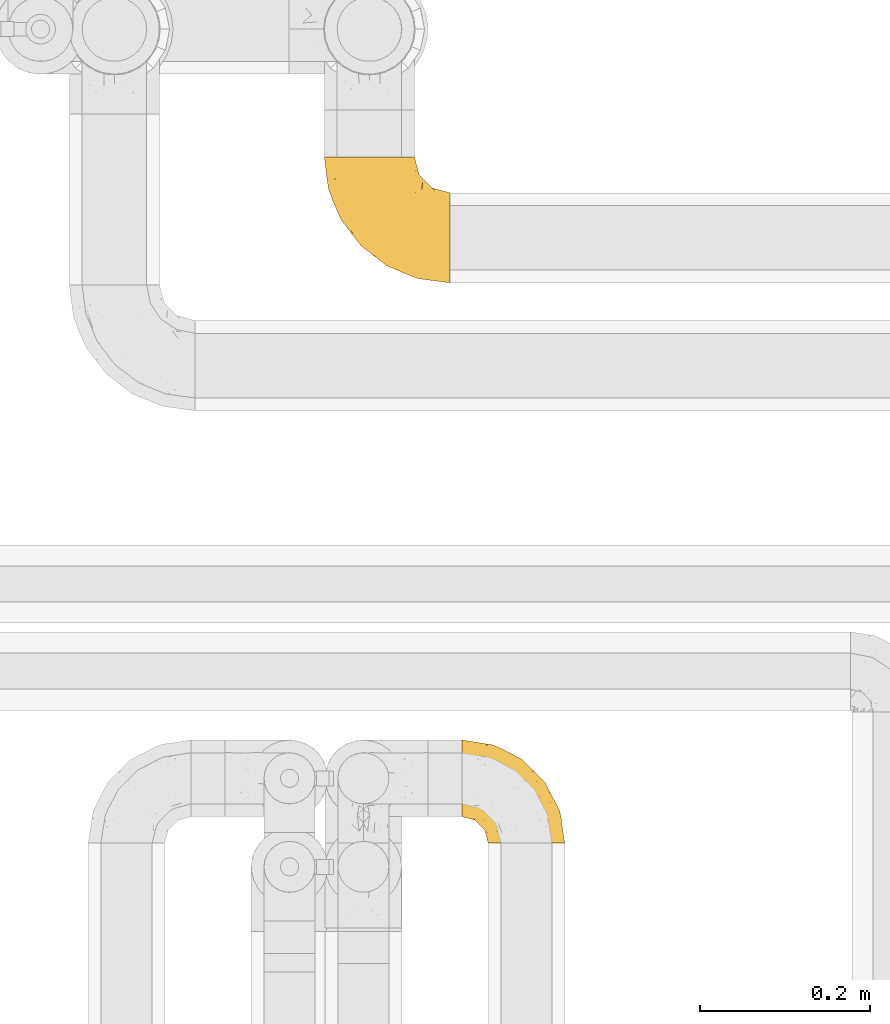
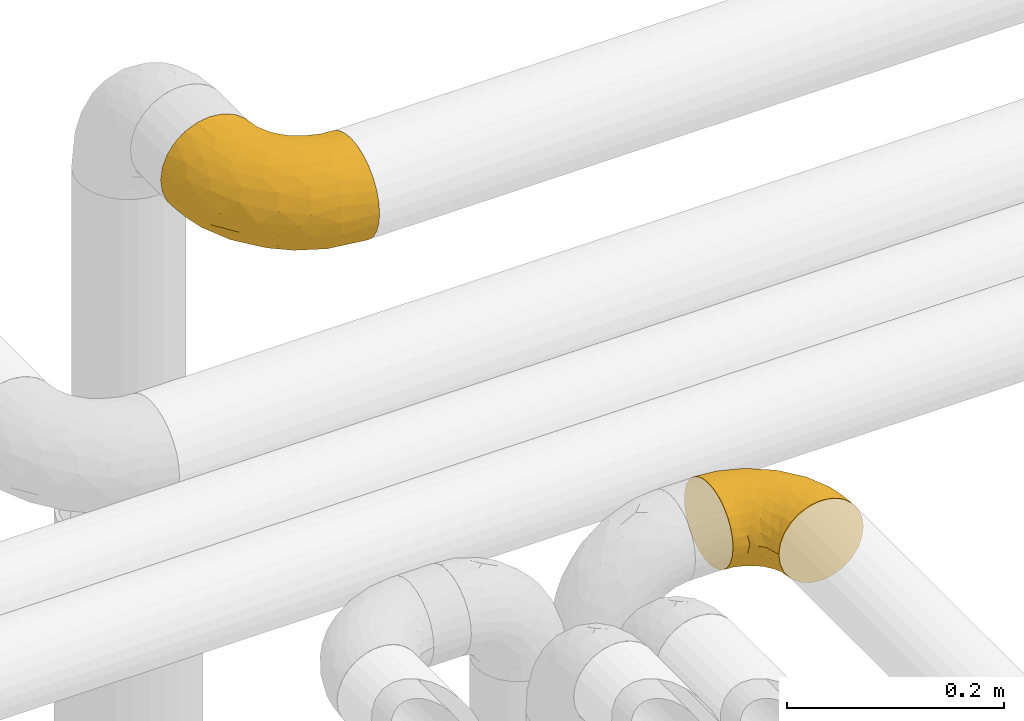
# One storey, part 323 of 827: 2 coverings.
"""IFC2X3 building model written with IfcOpenShell, lengths in millimetres."""

import ifcopenshell
import ifcopenshell.guid

model = None  # the IFC model being written
_history = None  # IfcOwnerHistory: only IFC2X3 demands one
_inside = {}  # id of a spatial element -> (the spatial element, [elements in it])
_under = {}  # id of a project, library or spatial element -> (it, [spatial elements below it])
_declared = {}  # id of a project -> (the project, [libraries it declares])
_typed = {}  # id of a type object -> (the type object, [elements of that type])
_made_of = {}  # id of a material, layer set ... -> (it, [elements and type objects made of it])


def new_model(schema):
    """Start an empty IFC model of exactly this schema.

    Asked for "IFC4X3", IfcOpenShell would pick the latest addendum, in which some entities
    have other attributes; the version numbers below select the first issue.
    IFC2X3 requires an IfcOwnerHistory on every rooted entity: one is made here for all.
    """
    global model, _history
    if schema == "IFC4X3":
        model = ifcopenshell.file(schema_version=(4, 3, 0, 0))
    else:
        model = ifcopenshell.file(schema=schema)
    _inside.clear()
    _under.clear()
    _declared.clear()
    _typed.clear()
    _made_of.clear()
    _history = None
    if model.schema == "IFC2X3":
        org = make("IfcOrganization", Name="unknown")
        user = make(
            "IfcPersonAndOrganization",
            ThePerson=make("IfcPerson", FamilyName="unknown"),
            TheOrganization=org,
        )
        app = make(
            "IfcApplication",
            ApplicationDeveloper=org,
            Version="unknown",
            ApplicationFullName="unknown",
            ApplicationIdentifier="unknown",
        )
        _history = make(
            "IfcOwnerHistory",
            OwningUser=user,
            OwningApplication=app,
            ChangeAction="ADDED",
            CreationDate=0,
        )
    return model


def make(cls, **values):
    """One entity of the class cls with the attributes given. An attribute that is None is left unset."""
    return model.create_entity(
        cls, **{name: value for name, value in values.items() if value is not None}
    )


def entity(cls, *values):
    """Any entity or typed value of the class cls, its attributes in the order of the schema. None: left unset."""
    e = model.create_entity(cls)
    for i, value in enumerate(values):
        if value is not None:
            e[i] = value
    return e


def rooted(cls, **values):
    """An entity with a GlobalId (a new one), such as an element, a storey or a relation."""
    return make(cls, GlobalId=ifcopenshell.guid.new(), OwnerHistory=_history, **values)


def si_unit(unit_type, name, prefix=None):
    """IfcSIUnit, for example si_unit("LENGTHUNIT", "METRE", prefix="MILLI")."""
    return make("IfcSIUnit", UnitType=unit_type, Prefix=prefix, Name=name)


def converted_unit(unit_type, name, factor, base, dimensions=None, offset=None):
    """IfcConversionBasedUnit, such as the inch: factor (a typed value) times the base unit."""
    return make(
        "IfcConversionBasedUnit"
        if offset is None
        else "IfcConversionBasedUnitWithOffset",
        ConversionOffset=offset,
        Dimensions=None
        if dimensions is None
        else entity("IfcDimensionalExponents", *dimensions),
        UnitType=unit_type,
        Name=name,
        ConversionFactor=make(
            "IfcMeasureWithUnit", ValueComponent=factor, UnitComponent=base
        ),
    )


def derived_unit(unit_type, elements):
    """IfcDerivedUnit: a product of units, each with its exponent."""
    return make(
        "IfcDerivedUnit",
        Elements=[
            make("IfcDerivedUnitElement", Unit=unit, Exponent=power)
            for unit, power in elements
        ],
        UnitType=unit_type,
    )


def assignment(units):
    """IfcUnitAssignment: the units of a project."""
    return None if units is None else make("IfcUnitAssignment", Units=units)


def point(xyz):
    """IfcCartesianPoint."""
    return None if xyz is None else make("IfcCartesianPoint", Coordinates=xyz)


def direction(xyz):
    """IfcDirection."""
    return None if xyz is None else make("IfcDirection", DirectionRatios=xyz)


def frame(location, z_axis=None, x_axis=None):
    """IfcAxis2Placement3D, a coordinate frame: its origin and axes. An axis left out is left unset."""
    return make(
        "IfcAxis2Placement3D",
        Location=point(location),
        Axis=direction(z_axis),
        RefDirection=direction(x_axis),
    )


def origin():
    """The frame at (0, 0, 0) with its axes left unset."""
    return frame((0.0, 0.0, 0.0))


def place(relative_to, where):
    """IfcLocalPlacement: puts the frame where relative to a parent placement (None: the world)."""
    return make(
        "IfcLocalPlacement", PlacementRelTo=relative_to, RelativePlacement=where
    )


def context(
    kind, dimensions, precision=None, world=None, true_north=None, identifier=None
):
    """IfcGeometricRepresentationContext, for example the 3D "Model" context."""
    return make(
        "IfcGeometricRepresentationContext",
        ContextIdentifier=identifier,
        ContextType=kind,
        CoordinateSpaceDimension=dimensions,
        Precision=precision,
        WorldCoordinateSystem=world,
        TrueNorth=true_north,
    )


def subcontext(parent, identifier, kind, view, scale=None):
    """IfcGeometricRepresentationSubContext, for example "Body" below "Model"."""
    return make(
        "IfcGeometricRepresentationSubContext",
        ContextIdentifier=identifier,
        ContextType=kind,
        ParentContext=parent,
        TargetScale=scale,
        TargetView=view,
    )


def project(units=None, contexts=None):
    """IfcProject with its units and contexts."""
    return rooted(
        "IfcProject",
        Name="project",
        RepresentationContexts=contexts,
        UnitsInContext=assignment(units),
    )


def spatial(cls, under=None, at=None, **own):
    """A site, building, storey or space (cls), placed at a placement, below another one or the project."""
    s = rooted(cls, ObjectPlacement=at, **own)
    if under is not None:
        _under.setdefault(under.id(), (under, []))[1].append(s)
    return s


def faces_of(points, faces, orient=None, outer=None):
    """IfcFace entities. A face is a list of loops; a loop is a list of indices into points, from 0.

    orient and outer hold one flag for each loop. By default every Orientation is true, the
    first loop of a face is its IfcFaceOuterBound and the others are IfcFaceBound.
    """
    made = []
    for i, loops in enumerate(faces):
        bounds = []
        for j, loop in enumerate(loops):
            is_outer = j == 0 if outer is None else outer[i][j]
            bounds.append(
                make(
                    "IfcFaceOuterBound" if is_outer else "IfcFaceBound",
                    Bound=make("IfcPolyLoop", Polygon=[points[k] for k in loop]),
                    Orientation=True if orient is None else orient[i][j],
                )
            )
        made.append(make("IfcFace", Bounds=bounds))
    return made


def faceted_brep(points, faces, orient=None, outer=None, voids=None):
    """IfcFacetedBrep: a solid bounded by flat faces; with voids (closed shells), ...WithVoids."""
    shared = [point(p) for p in points]
    hull = make("IfcClosedShell", CfsFaces=faces_of(shared, faces, orient, outer))
    if voids is None:
        return make("IfcFacetedBrep", Outer=hull)
    return make(
        "IfcFacetedBrepWithVoids",
        Outer=hull,
        Voids=[
            make(cls, CfsFaces=faces_of(shared, fs, o, b)) for cls, fs, o, b in voids
        ],
    )


def shape(context_of_items, identifier, shape_type, items):
    """IfcShapeRepresentation: the items that make up one representation, for example the "Body"."""
    return make(
        "IfcShapeRepresentation",
        ContextOfItems=context_of_items,
        RepresentationIdentifier=identifier,
        RepresentationType=shape_type,
        Items=items,
    )


def made_of(thing, what):
    """Note that an element or type object is made of a material, layer set ...; save() writes the relation."""
    if what is not None:
        _made_of.setdefault(what.id(), (what, []))[1].append(thing)
    return thing


def element(
    cls,
    number,
    at=None,
    inside=None,
    cuts=None,
    type_object=None,
    material=None,
    context=None,
    identifier="Body",
    shape_type=None,
    held_by="IfcProductDefinitionShape",
    body=None,
    shapes=None,
    **own,
):
    """One element of the class cls, such as IfcWall. Its Tag is "e" and its number.

    at: its placement. inside: the storey or other place that contains it. cuts: it is an
    opening in that element (IfcRelVoidsElement). A single representation is given by context,
    identifier, shape_type and body (its items); several are given by shapes. held_by: the class
    of the entity that holds the representations. save() writes the other relations.
    """
    e = rooted(cls, Tag="e%d" % number, ObjectPlacement=at, **own)
    if body is not None:
        shapes = [shape(context, identifier, shape_type, body)]
    if shapes is not None:
        e.Representation = make(held_by, Representations=shapes)
    if inside is not None:
        _inside.setdefault(inside.id(), (inside, []))[1].append(e)
    if cuts is not None:
        rooted(
            "IfcRelVoidsElement", RelatingBuildingElement=cuts, RelatedOpeningElement=e
        )
    if type_object is not None:
        _typed.setdefault(type_object.id(), (type_object, []))[1].append(e)
    return made_of(e, material)


def aggregate(whole, parts):
    """IfcRelAggregates: a whole, such as a stair, and the parts it consists of."""
    return rooted("IfcRelAggregates", RelatingObject=whole, RelatedObjects=parts)


def save(model, path):
    """Write the relations noted so far, then the file.

    IfcRelAggregates (storeys below a building ...), IfcRelContainedInSpatialStructure (elements
    in a storey), IfcRelDefinesByType, IfcRelAssociatesMaterial and IfcRelDeclares: one each for
    every whole, place, type object, material and project.
    """
    for whole, parts in _under.values():
        aggregate(whole, parts)
    for where, things in _inside.values():
        rooted(
            "IfcRelContainedInSpatialStructure",
            RelatedElements=things,
            RelatingStructure=where,
        )
    for kind, things in _typed.values():
        rooted("IfcRelDefinesByType", RelatedObjects=things, RelatingType=kind)
    for what, things in _made_of.values():
        rooted("IfcRelAssociatesMaterial", RelatedObjects=things, RelatingMaterial=what)
    for by, libraries in _declared.values():
        rooted("IfcRelDeclares", RelatingContext=by, RelatedDefinitions=libraries)
    model.write(path)


model = new_model("IFC2X3")

# Units and contexts
model_context = context("Model", 3, precision=0.01, world=origin(), true_north=direction((6.12303176911189e-17, 1.0)))
body_context = subcontext(model_context, "Body", "Model", "MODEL_VIEW")
ifc_project = project(units=[si_unit("LENGTHUNIT", "METRE", prefix="MILLI"), si_unit("AREAUNIT", "SQUARE_METRE"), si_unit("VOLUMEUNIT", "CUBIC_METRE"), converted_unit("PLANEANGLEUNIT", "DEGREE", entity("IfcRatioMeasure", 0.0174532925199433), si_unit("PLANEANGLEUNIT", "RADIAN"), dimensions=[0, 0, 0, 0, 0, 0, 0]), si_unit("MASSUNIT", "GRAM", prefix="KILO"), derived_unit("MASSDENSITYUNIT", [(si_unit("MASSUNIT", "GRAM", prefix="KILO"), 1), (si_unit("LENGTHUNIT", "METRE"), -3)]), derived_unit("MOMENTOFINERTIAUNIT", [(si_unit("LENGTHUNIT", "METRE"), 4)]), si_unit("TIMEUNIT", "SECOND"), si_unit("FREQUENCYUNIT", "HERTZ"), si_unit("THERMODYNAMICTEMPERATUREUNIT", "DEGREE_CELSIUS"), derived_unit("THERMALTRANSMITTANCEUNIT", [(si_unit("MASSUNIT", "GRAM", prefix="KILO"), 1), (si_unit("THERMODYNAMICTEMPERATUREUNIT", "KELVIN"), -1), (si_unit("TIMEUNIT", "SECOND"), -3)]), derived_unit("VOLUMETRICFLOWRATEUNIT", [(si_unit("LENGTHUNIT", "METRE"), 3), (si_unit("TIMEUNIT", "SECOND"), -1)]), derived_unit("MASSFLOWRATEUNIT", [(si_unit("MASSUNIT", "GRAM", prefix="KILO"), 1), (si_unit("TIMEUNIT", "SECOND"), -1)]), derived_unit("ROTATIONALFREQUENCYUNIT", [(si_unit("TIMEUNIT", "SECOND"), -1)]), si_unit("ELECTRICCURRENTUNIT", "AMPERE"), si_unit("ELECTRICVOLTAGEUNIT", "VOLT"), si_unit("POWERUNIT", "WATT"), si_unit("FORCEUNIT", "NEWTON", prefix="KILO"), si_unit("ILLUMINANCEUNIT", "LUX"), si_unit("LUMINOUSFLUXUNIT", "LUMEN"), si_unit("LUMINOUSINTENSITYUNIT", "CANDELA"), derived_unit("USERDEFINED", [(si_unit("MASSUNIT", "GRAM", prefix="KILO"), -1), (si_unit("LENGTHUNIT", "METRE"), -2), (si_unit("TIMEUNIT", "SECOND"), 3), (si_unit("LUMINOUSFLUXUNIT", "LUMEN"), 1)]), derived_unit("LINEARVELOCITYUNIT", [(si_unit("LENGTHUNIT", "METRE"), 1), (si_unit("TIMEUNIT", "SECOND"), -1)]), si_unit("PRESSUREUNIT", "PASCAL"), derived_unit("USERDEFINED", [(si_unit("LENGTHUNIT", "METRE"), -2), (si_unit("MASSUNIT", "GRAM", prefix="KILO"), 1), (si_unit("TIMEUNIT", "SECOND"), -2)]), derived_unit("LINEARFORCEUNIT", [(si_unit("MASSUNIT", "GRAM", prefix="KILO"), 1), (si_unit("LENGTHUNIT", "METRE"), 1), (si_unit("TIMEUNIT", "SECOND"), -2), (si_unit("LENGTHUNIT", "METRE"), -1)]), derived_unit("PLANARFORCEUNIT", [(si_unit("MASSUNIT", "GRAM", prefix="KILO"), 1), (si_unit("LENGTHUNIT", "METRE"), 1), (si_unit("TIMEUNIT", "SECOND"), -2), (si_unit("LENGTHUNIT", "METRE"), -2)])], contexts=[model_context])

# Site, building, storey
site_placement = place(None, origin())
site = spatial("IfcSite", under=ifc_project, at=site_placement, CompositionType="ELEMENT")
building_placement = place(site_placement, origin())
building = spatial("IfcBuilding", under=site, at=building_placement, CompositionType="ELEMENT")
storey_placement = place(building_placement, frame((0.0, 0.0, 28200.0)))
storey = spatial("IfcBuildingStorey", under=building, at=storey_placement, Name="08", CompositionType="ELEMENT", Elevation=28200.0)

# Coverings
covering_1_placement = place(storey_placement, frame((31701.06, 19053.07, 2945.35)))
element("IfcCovering", 1, at=covering_1_placement, inside=storey, Name=":ADSK_", ObjectType=":ADSK_", PredefinedType="INSULATION", context=body_context, shape_type="Brep", body=[
    faceted_brep([(149.65, 2.92, 66.44), (149.65, 1.6, 54.65), (149.65, 2.93, 42.84), (149.65, 6.85, 31.62), (149.65, 13.18, 21.56), (149.65, 21.58, 13.16), (149.65, 31.64, 6.84), (149.65, 42.85, 2.92), (149.65, 54.65, 1.6), (149.65, 66.46, 2.93), (149.65, 77.67, 6.85), (149.65, 87.73, 13.18), (149.65, 96.13, 21.58), (149.65, 102.45, 31.64), (149.65, 106.37, 42.85), (149.65, 107.7, 54.65), (149.65, 106.36, 66.46), (149.65, 102.44, 77.67), (149.65, 96.11, 87.73), (149.65, 87.71, 96.13), (149.65, 77.65, 102.45), (149.65, 66.44, 106.37), (149.65, 54.65, 107.7), (149.65, 42.84, 106.36), (149.65, 31.62, 102.44), (149.65, 21.56, 96.11), (149.65, 13.16, 87.71), (149.65, 6.84, 77.65), (105.89, 149.65, 40.91), (100.59, 149.65, 28.12), (92.16, 149.65, 17.13), (81.17, 149.65, 8.7), (68.38, 149.65, 3.4), (54.65, 149.65, 1.6), (40.91, 149.65, 3.4), (28.12, 149.65, 8.7), (17.13, 149.65, 17.13), (8.7, 149.65, 28.12), (3.4, 149.65, 40.91), (1.6, 149.65, 54.65), (3.4, 149.65, 68.38), (8.7, 149.65, 81.17), (17.13, 149.65, 92.16), (28.12, 149.65, 100.59), (40.91, 149.65, 105.89), (54.65, 149.65, 107.7), (68.38, 149.65, 105.89), (81.17, 149.65, 100.59), (92.16, 149.65, 92.16), (100.59, 149.65, 81.17), (105.89, 149.65, 68.38), (107.7, 149.65, 54.65), (14.05, 123.27, 85.53), (9.45, 114.15, 73.42), (22.36, 92.97, 83.77), (4.7, 124.11, 64.22), (6.64, 111.33, 54.65), (81.47, 42.13, 96.72), (56.83, 56.83, 93.36), (64.02, 40.31, 84.47), (34.04, 61.55, 71.37), (21.43, 75.62, 54.65), (44.96, 44.96, 54.65), (49.8, 91.12, 103.47), (35.43, 109.83, 100.91), (42.1, 88.02, 99.1), (43.59, 119.19, 105.43), (57.88, 99.11, 106.79), (91.8, 27.97, 89.81), (88.01, 21.92, 79.59), (115.65, 12.94, 81.29), (18.94, 88.29, 74.01), (12.83, 95.35, 64.14), (24.96, 113.84, 94.75), (111.33, 6.64, 54.65), (113.8, 8.58, 70.74), (60.89, 33.39, 68.3), (86.24, 17.23, 66.05), (65.84, 61.99, 100.73), (124.58, 47.9, 106.78), (121.36, 37.72, 103.6), (72.79, 93.81, 107.7), (66.04, 107.05, 107.7), (59.29, 120.29, 107.7), (73.26, 73.26, 106.07), (121.69, 18.58, 90.59), (109.82, 29.72, 97.43), (40.11, 64.31, 84.51), (36.57, 82.84, 93.3), (93.81, 72.79, 107.7), (83.3, 83.3, 107.7), (136.6, 56.71, 107.7), (120.29, 59.29, 107.7), (99.11, 57.88, 106.79), (107.05, 66.04, 107.7), (91.12, 49.8, 103.47), (75.62, 21.43, 54.65), (56.97, 134.97, 107.7), (126.65, 108.79, 76.99), (116.55, 110.84, 84.28), (120.09, 101.53, 91.11), (76.06, 111.84, 106.26), (83.69, 119.98, 102.6), (71.88, 123.54, 106.08), (66.92, 134.54, 106.56), (110.43, 80.57, 105.36), (121.31, 69.55, 106.74), (81.0, 134.56, 101.59), (113.32, 128.67, 54.65), (111.09, 136.98, 54.65), (109.14, 133.56, 67.71), (95.86, 131.66, 91.36), (99.07, 117.75, 94.33), (106.92, 118.23, 87.1), (131.39, 110.55, 65.84), (136.98, 111.09, 54.65), (128.67, 113.32, 54.65), (117.07, 120.2, 68.92), (96.39, 105.95, 100.82), (106.61, 127.69, 79.83), (103.72, 139.88, 77.13), (92.14, 92.14, 105.9), (107.13, 93.82, 101.53), (98.03, 82.28, 106.72), (88.38, 130.86, 97.75), (130.66, 78.78, 103.08), (135.45, 67.58, 106.39), (123.57, 90.58, 98.1), (137.75, 90.23, 95.02), (133.2, 99.39, 86.9), (138.8, 105.17, 74.42), (120.99, 120.99, 54.65), (84.53, 104.59, 105.28), (108.72, 108.24, 92.87), (95.86, 131.66, 17.93), (130.67, 78.8, 6.22), (109.13, 133.57, 41.58), (93.81, 72.79, 1.6), (98.02, 82.27, 2.57), (110.43, 80.59, 3.94), (131.4, 110.55, 43.46), (126.66, 108.79, 32.32), (117.08, 120.2, 40.38), (108.74, 108.25, 16.44), (96.31, 106.06, 8.47), (99.11, 117.78, 15.01), (123.58, 90.6, 11.21), (107.12, 93.87, 7.78), (72.79, 93.81, 1.6), (66.04, 107.05, 1.6), (76.07, 111.89, 3.04), (56.97, 134.97, 1.6), (66.92, 134.54, 2.73), (120.29, 59.29, 1.6), (107.05, 66.04, 1.6), (121.26, 69.56, 2.55), (84.46, 104.56, 3.98), (83.69, 119.98, 6.69), (81.0, 134.56, 7.7), (71.88, 123.54, 3.21), (137.76, 90.25, 14.28), (133.21, 99.4, 22.42), (116.58, 110.83, 25.02), (120.1, 101.52, 18.18), (138.81, 105.18, 34.89), (136.6, 56.71, 1.6), (103.72, 139.89, 32.17), (106.96, 118.22, 22.23), (135.44, 67.6, 2.91), (88.38, 130.86, 11.54), (83.3, 83.3, 1.6), (92.12, 92.12, 3.38), (106.6, 127.71, 29.46), (59.29, 120.29, 1.6), (22.36, 92.97, 25.52), (14.05, 123.27, 23.76), (24.96, 113.84, 14.54), (35.43, 109.83, 8.38), (4.71, 124.03, 45.07), (9.45, 114.15, 35.87), (11.79, 98.04, 45.14), (57.88, 99.11, 2.5), (124.57, 47.9, 2.51), (121.37, 37.74, 5.68), (91.12, 49.8, 5.82), (56.83, 56.83, 15.93), (81.48, 42.16, 12.54), (64.05, 40.3, 24.81), (99.11, 57.88, 2.5), (73.26, 73.26, 3.22), (43.59, 119.19, 3.86), (19.5, 86.61, 35.85), (91.8, 27.99, 19.47), (121.7, 18.59, 18.68), (88.04, 21.92, 29.68), (123.34, 11.28, 27.95), (60.89, 33.39, 40.99), (34.04, 61.55, 37.92), (109.85, 29.73, 11.85), (42.1, 88.01, 10.19), (65.78, 62.08, 8.55), (113.81, 8.58, 38.53), (36.57, 82.84, 15.99), (40.12, 64.3, 24.79), (49.8, 91.12, 5.82), (86.08, 18.05, 40.56)], [[[0, 1, 2, 3, 4, 5, 6, 7, 8, 9, 10, 11, 12, 13, 14, 15, 16, 17, 18, 19, 20, 21, 22, 23, 24, 25, 26, 27]], [[28, 29, 30, 31, 32, 33, 34, 35, 36, 37, 38, 39, 40, 41, 42, 43, 44, 45, 46, 47, 48, 49, 50, 51]], [[52, 53, 54]], [[55, 39, 56]], [[57, 58, 59]], [[60, 61, 62]], [[63, 64, 65]], [[66, 63, 67]], [[68, 69, 70]], [[53, 71, 54]], [[41, 40, 53]], [[53, 72, 71]], [[73, 42, 52]], [[42, 41, 52]], [[74, 0, 75]], [[69, 76, 77]], [[43, 73, 64]], [[45, 44, 66]], [[57, 78, 58]], [[23, 79, 80]], [[67, 81, 82, 83]], [[67, 84, 81]], [[24, 23, 80]], [[25, 85, 26]], [[86, 85, 25]], [[42, 73, 43]], [[0, 27, 75]], [[25, 24, 86]], [[70, 26, 85]], [[0, 74, 1]], [[68, 85, 86]], [[66, 64, 63]], [[60, 59, 87]], [[54, 87, 88]], [[76, 60, 62]], [[84, 89, 90, 81]], [[79, 22, 91, 92]], [[77, 74, 75]], [[93, 92, 94, 89]], [[80, 86, 24]], [[40, 55, 53]], [[76, 59, 60]], [[93, 84, 95]], [[76, 62, 96]], [[55, 72, 53]], [[70, 27, 26]], [[75, 70, 69]], [[78, 84, 63]], [[93, 79, 92]], [[95, 86, 80]], [[77, 76, 96]], [[59, 69, 68]], [[57, 68, 86]], [[68, 57, 59]], [[59, 58, 87]], [[76, 69, 59]], [[88, 87, 58]], [[87, 54, 71]], [[86, 95, 57]], [[78, 57, 95]], [[84, 78, 95]], [[78, 63, 65]], [[58, 78, 65]], [[54, 88, 73]], [[84, 93, 89]], [[79, 95, 80]], [[79, 93, 95]], [[22, 79, 23]], [[66, 83, 97, 45]], [[84, 67, 63]], [[83, 66, 67]], [[64, 44, 43]], [[64, 66, 44]], [[65, 73, 88]], [[53, 52, 41]], [[73, 52, 54]], [[73, 65, 64]], [[65, 88, 58]], [[39, 55, 40]], [[72, 55, 56]], [[56, 61, 72]], [[60, 72, 61]], [[72, 60, 71]], [[87, 71, 60]], [[27, 70, 75]], [[68, 70, 85]], [[74, 77, 96]], [[69, 77, 75]], [[98, 99, 100]], [[46, 45, 97]], [[101, 102, 103]], [[103, 104, 83]], [[105, 94, 106]], [[107, 103, 102]], [[108, 109, 51, 110]], [[111, 112, 113]], [[114, 115, 116]], [[47, 104, 107]], [[110, 117, 108]], [[49, 48, 111]], [[102, 118, 112]], [[119, 120, 111]], [[50, 49, 120]], [[121, 122, 118]], [[105, 123, 89]], [[124, 48, 107]], [[20, 19, 125]], [[121, 81, 90]], [[117, 119, 99]], [[21, 20, 126]], [[22, 21, 91]], [[105, 125, 127]], [[110, 51, 50]], [[19, 128, 125]], [[16, 15, 115]], [[129, 98, 100]], [[126, 91, 21]], [[128, 129, 127]], [[122, 123, 105]], [[114, 117, 98]], [[17, 16, 130]], [[18, 128, 19]], [[129, 18, 17]], [[125, 106, 126]], [[115, 114, 16]], [[130, 129, 17]], [[114, 98, 130]], [[117, 116, 131, 108]], [[99, 119, 113]], [[122, 121, 123]], [[92, 126, 106]], [[105, 127, 122]], [[132, 121, 118]], [[114, 130, 16]], [[129, 130, 98]], [[50, 120, 110]], [[129, 128, 18]], [[125, 128, 127]], [[125, 126, 20]], [[91, 126, 92]], [[105, 89, 94]], [[105, 106, 125]], [[94, 92, 106]], [[100, 122, 127]], [[118, 122, 133]], [[112, 118, 133]], [[132, 118, 102]], [[132, 102, 101]], [[81, 121, 132]], [[82, 103, 83]], [[132, 101, 81]], [[104, 47, 46]], [[124, 107, 102]], [[48, 47, 107]], [[113, 112, 133]], [[112, 111, 124]], [[99, 113, 133]], [[111, 113, 119]], [[99, 133, 100]], [[117, 99, 98]], [[122, 100, 133]], [[127, 129, 100]], [[103, 82, 101]], [[81, 101, 82]], [[112, 124, 102]], [[48, 124, 111]], [[104, 103, 107]], [[46, 97, 104]], [[111, 120, 49]], [[83, 104, 97]], [[110, 120, 119]], [[117, 110, 119]], [[116, 117, 114]], [[123, 90, 89]], [[90, 123, 121]], [[30, 29, 134]], [[11, 10, 135]], [[51, 109, 108, 136]], [[137, 138, 139]], [[140, 141, 142]], [[143, 144, 145]], [[146, 139, 147]], [[148, 149, 150]], [[151, 32, 152]], [[153, 154, 155]], [[156, 150, 157]], [[158, 157, 159]], [[108, 142, 136]], [[31, 158, 152]], [[160, 161, 12]], [[162, 163, 143]], [[140, 142, 116]], [[142, 141, 162]], [[14, 164, 140]], [[14, 140, 115]], [[9, 8, 165]], [[160, 12, 11]], [[141, 164, 161]], [[13, 12, 161]], [[14, 115, 15]], [[28, 166, 29]], [[135, 139, 146]], [[141, 163, 162]], [[135, 146, 160]], [[143, 167, 162]], [[29, 166, 134]], [[116, 142, 108, 131]], [[165, 153, 168]], [[10, 9, 168]], [[168, 135, 10]], [[138, 147, 139]], [[158, 169, 157]], [[14, 13, 164]], [[116, 115, 140]], [[145, 167, 143]], [[135, 160, 11]], [[168, 153, 155]], [[138, 170, 171]], [[157, 144, 156]], [[147, 144, 143]], [[161, 164, 13]], [[140, 164, 141]], [[142, 172, 136]], [[136, 172, 166]], [[161, 160, 146]], [[165, 168, 9]], [[155, 139, 135]], [[139, 154, 137]], [[168, 155, 135]], [[139, 155, 154]], [[144, 147, 171]], [[163, 147, 143]], [[156, 144, 171]], [[157, 169, 145]], [[171, 148, 156]], [[173, 159, 149]], [[159, 157, 150]], [[152, 159, 173]], [[159, 152, 158]], [[31, 30, 158]], [[169, 30, 134]], [[157, 145, 144]], [[167, 134, 172]], [[134, 167, 145]], [[172, 142, 162]], [[162, 167, 172]], [[163, 141, 161]], [[161, 146, 163]], [[147, 163, 146]], [[148, 150, 156]], [[149, 159, 150]], [[30, 169, 158]], [[145, 169, 134]], [[151, 33, 32]], [[31, 152, 32]], [[152, 173, 151]], [[28, 51, 136]], [[134, 166, 172]], [[28, 136, 166]], [[147, 138, 171]], [[170, 138, 137]], [[170, 148, 171]], [[174, 175, 176]], [[35, 34, 177]], [[178, 179, 180]], [[181, 173, 149, 148]], [[182, 183, 184]], [[185, 186, 187]], [[188, 189, 137]], [[190, 33, 151, 173]], [[191, 179, 174]], [[34, 190, 177]], [[39, 38, 178]], [[192, 193, 194]], [[4, 3, 195]], [[175, 179, 37]], [[38, 37, 179]], [[35, 176, 36]], [[196, 62, 197]], [[181, 190, 173]], [[37, 36, 175]], [[183, 6, 198]], [[189, 148, 170, 137]], [[185, 199, 200]], [[3, 2, 201]], [[202, 185, 203]], [[8, 7, 182]], [[200, 184, 186]], [[183, 7, 6]], [[181, 189, 204]], [[200, 189, 184]], [[5, 198, 6]], [[187, 203, 185]], [[195, 3, 201]], [[205, 196, 194]], [[62, 61, 197]], [[186, 198, 192]], [[180, 179, 191]], [[2, 1, 74]], [[198, 193, 192]], [[193, 5, 4]], [[194, 193, 195]], [[2, 74, 201]], [[5, 193, 198]], [[205, 74, 96]], [[188, 137, 154, 153]], [[62, 196, 96]], [[56, 178, 180]], [[198, 184, 183]], [[184, 188, 182]], [[203, 197, 191]], [[205, 194, 201]], [[187, 192, 194]], [[192, 187, 186]], [[194, 196, 187]], [[197, 187, 196]], [[197, 203, 187]], [[202, 174, 176]], [[200, 186, 185]], [[184, 198, 186]], [[199, 185, 202]], [[189, 200, 204]], [[174, 202, 203]], [[176, 177, 199]], [[189, 181, 148]], [[190, 181, 204]], [[190, 204, 177]], [[190, 34, 33]], [[188, 153, 182]], [[189, 188, 184]], [[182, 153, 165, 8]], [[183, 182, 7]], [[199, 177, 204]], [[35, 177, 176]], [[176, 175, 36]], [[179, 175, 174]], [[200, 199, 204]], [[176, 199, 202]], [[203, 191, 174]], [[180, 197, 61]], [[197, 180, 191]], [[61, 56, 180]], [[39, 178, 56]], [[38, 179, 178]], [[194, 195, 201]], [[4, 195, 193]], [[74, 205, 201]], [[96, 196, 205]]]),
])
covering_2_placement = place(storey_placement, frame((31863.07, 18393.61, 2953.25)))
element("IfcCovering", 2, at=covering_2_placement, inside=storey, Name=":ADSK_", ObjectType=":ADSK_", PredefinedType="INSULATION", context=body_context, shape_type="Brep", body=[
    faceted_brep([(1.6, 87.65, 90.76), (1.6, 97.19, 87.42), (1.6, 105.75, 82.04), (1.6, 112.9, 74.89), (1.6, 118.28, 66.33), (1.6, 121.61, 56.79), (1.6, 122.75, 46.75), (1.6, 121.61, 36.69), (1.6, 118.27, 27.15), (1.6, 112.89, 18.59), (1.6, 105.74, 11.44), (1.6, 97.18, 6.06), (1.6, 87.64, 2.73), (1.6, 77.6, 1.6), (1.6, 67.54, 2.73), (1.6, 58.0, 6.07), (1.6, 49.44, 11.45), (1.6, 42.29, 18.6), (1.6, 36.91, 27.16), (1.6, 33.58, 36.7), (1.6, 32.45, 46.75), (1.6, 33.58, 56.8), (1.6, 36.92, 66.34), (1.6, 42.3, 74.9), (1.6, 49.45, 82.05), (1.6, 58.01, 87.43), (1.6, 67.55, 90.76), (1.6, 77.6, 91.9), (33.98, 1.6, 35.06), (38.49, 1.6, 24.17), (45.67, 1.6, 14.82), (55.02, 1.6, 7.64), (65.91, 1.6, 3.13), (77.6, 1.6, 1.6), (89.28, 1.6, 3.13), (100.17, 1.6, 7.64), (109.52, 1.6, 14.82), (116.7, 1.6, 24.17), (121.21, 1.6, 35.06), (122.75, 1.6, 46.75), (121.21, 1.6, 58.43), (116.7, 1.6, 69.32), (109.52, 1.6, 78.67), (100.17, 1.6, 85.85), (89.28, 1.6, 90.36), (77.6, 1.6, 91.9), (65.91, 1.6, 90.36), (55.02, 1.6, 85.85), (45.67, 1.6, 78.67), (38.49, 1.6, 69.32), (33.98, 1.6, 58.43), (32.45, 1.6, 46.75), (72.81, 99.61, 46.75), (77.17, 95.26, 55.2), (86.21, 86.21, 46.75), (116.82, 39.03, 46.75), (118.49, 30.75, 54.53), (119.23, 23.8, 46.75), (105.14, 60.8, 59.63), (85.37, 85.37, 62.07), (89.33, 73.64, 71.86), (116.14, 31.01, 62.65), (105.06, 49.14, 71.33), (112.15, 23.88, 72.93), (22.95, 82.74, 91.2), (89.91, 43.48, 86.31), (103.39, 29.47, 80.89), (93.6, 56.38, 79.49), (51.41, 72.18, 90.68), (67.71, 72.24, 86.84), (43.53, 87.6, 87.38), (30.91, 107.24, 76.87), (23.58, 101.1, 83.73), (50.07, 95.16, 81.03), (30.68, 71.81, 91.9), (43.01, 63.57, 91.9), (55.34, 55.34, 91.9), (83.48, 23.66, 91.03), (94.96, 20.55, 87.58), (57.29, 107.97, 56.52), (39.03, 116.82, 46.75), (30.66, 117.03, 60.4), (71.81, 30.68, 91.9), (73.63, 21.51, 91.9), (75.46, 12.33, 91.9), (51.57, 106.17, 67.87), (73.13, 52.37, 90.35), (23.16, 114.51, 69.57), (23.8, 119.23, 46.75), (75.6, 78.37, 79.91), (12.33, 75.46, 91.9), (21.51, 73.63, 91.9), (50.46, 101.51, 74.99), (99.61, 72.81, 46.75), (63.57, 43.01, 91.9), (21.26, 92.6, 88.53), (69.54, 91.86, 72.65), (108.21, 55.92, 46.75), (68.42, 99.01, 62.97), (55.92, 108.21, 46.75), (19.36, 32.05, 66.2), (15.76, 30.22, 56.6), (26.13, 23.37, 59.89), (62.78, 28.43, 90.95), (63.65, 16.44, 90.22), (24.34, 37.1, 76.64), (28.46, 28.88, 71.58), (33.53, 33.93, 79.99), (39.46, 50.17, 89.54), (51.05, 40.57, 89.97), (10.94, 47.62, 81.32), (14.55, 39.9, 74.56), (22.21, 47.92, 84.15), (57.05, 34.27, 90.37), (54.0, 24.65, 87.82), (29.19, 62.6, 90.98), (18.85, 66.18, 90.96), (52.84, 11.74, 85.14), (31.47, 13.89, 58.11), (28.31, 17.02, 46.75), (43.0, 15.86, 78.39), (16.9, 57.71, 88.22), (35.98, 9.11, 66.06), (33.91, 18.55, 68.6), (9.97, 34.74, 63.78), (25.93, 54.95, 88.42), (35.61, 57.35, 90.61), (47.45, 22.03, 83.8), (38.26, 24.8, 77.98), (11.7, 69.07, 91.22), (30.13, 42.31, 83.46), (12.12, 29.63, 46.75), (17.02, 28.31, 46.75), (44.39, 30.23, 84.66), (39.83, 40.13, 86.33), (22.67, 22.67, 46.75), (29.63, 12.12, 46.75), (43.0, 15.86, 15.1), (47.45, 22.03, 9.69), (38.26, 24.8, 15.52), (44.38, 30.23, 8.83), (31.47, 13.88, 35.39), (10.93, 47.61, 12.18), (21.51, 73.63, 1.6), (18.84, 66.17, 2.53), (11.7, 69.07, 2.27), (15.76, 30.22, 36.9), (19.36, 32.04, 27.31), (26.14, 23.36, 33.62), (25.94, 54.93, 5.07), (22.21, 47.91, 9.36), (16.9, 57.69, 5.27), (35.98, 9.1, 27.43), (73.63, 21.51, 1.6), (75.46, 12.33, 1.6), (30.12, 42.29, 10.05), (24.33, 37.09, 16.87), (52.84, 11.74, 8.35), (63.65, 16.44, 3.27), (71.81, 30.68, 1.6), (28.45, 28.86, 21.94), (9.97, 34.74, 29.72), (43.01, 63.57, 1.6), (55.34, 55.34, 1.6), (39.46, 50.17, 3.96), (12.33, 75.46, 1.6), (14.54, 39.89, 18.95), (62.78, 28.43, 2.54), (57.05, 34.27, 3.12), (63.57, 43.01, 1.6), (29.2, 62.59, 2.51), (51.05, 40.57, 3.52), (39.81, 40.13, 7.17), (30.68, 71.81, 1.6), (33.52, 33.92, 13.52), (35.61, 57.34, 2.88), (54.0, 24.65, 5.67), (33.91, 18.54, 24.89), (103.39, 29.47, 12.6), (89.91, 43.48, 7.18), (93.6, 56.4, 14.0), (105.05, 49.17, 22.16), (89.27, 73.69, 21.61), (73.13, 52.37, 3.14), (67.67, 72.26, 6.65), (69.49, 91.88, 20.82), (85.36, 85.36, 31.41), (94.96, 20.55, 5.91), (83.48, 23.66, 2.46), (105.14, 60.8, 33.87), (116.13, 31.02, 30.84), (118.49, 30.75, 38.96), (112.15, 23.9, 20.56), (51.41, 72.17, 2.81), (43.51, 87.59, 6.1), (22.95, 82.74, 2.29), (30.66, 117.03, 33.08), (30.91, 107.23, 16.61), (57.3, 107.97, 36.96), (23.58, 101.08, 9.75), (51.56, 106.17, 25.61), (68.41, 99.01, 30.5), (23.16, 114.5, 23.91), (50.07, 95.15, 12.45), (50.45, 101.5, 18.49), (21.25, 92.59, 4.96), (75.56, 78.38, 13.56), (77.16, 95.27, 38.28)], [[[0, 1, 2, 3, 4, 5, 6, 7, 8, 9, 10, 11, 12, 13, 14, 15, 16, 17, 18, 19, 20, 21, 22, 23, 24, 25, 26, 27]], [[28, 29, 30, 31, 32, 33, 34, 35, 36, 37, 38, 39, 40, 41, 42, 43, 44, 45, 46, 47, 48, 49, 50, 51]], [[52, 53, 54]], [[55, 56, 57]], [[58, 59, 60]], [[61, 62, 63]], [[27, 64, 0]], [[65, 66, 67]], [[41, 40, 61]], [[68, 69, 70]], [[66, 43, 42]], [[63, 42, 41]], [[71, 72, 73]], [[72, 2, 1]], [[68, 74, 75, 76]], [[45, 44, 77]], [[43, 78, 44]], [[79, 80, 81]], [[77, 82, 83, 84, 45]], [[79, 81, 85]], [[71, 2, 72]], [[65, 86, 77]], [[4, 81, 5]], [[66, 65, 78]], [[4, 3, 87]], [[81, 88, 5]], [[63, 66, 42]], [[68, 70, 64]], [[67, 60, 89]], [[71, 3, 2]], [[64, 27, 90, 91, 74]], [[92, 71, 73]], [[40, 57, 56]], [[59, 93, 54]], [[86, 76, 94, 82]], [[1, 0, 95]], [[58, 62, 61]], [[60, 96, 89]], [[85, 81, 87]], [[56, 97, 58]], [[65, 67, 69]], [[87, 81, 4]], [[67, 89, 69]], [[61, 63, 41]], [[95, 72, 1]], [[73, 72, 70]], [[69, 73, 70]], [[73, 89, 96]], [[3, 71, 87]], [[85, 87, 71]], [[58, 61, 56]], [[59, 58, 93]], [[76, 86, 68]], [[69, 89, 73]], [[68, 86, 69]], [[65, 69, 86]], [[68, 64, 74]], [[95, 64, 70]], [[98, 79, 85]], [[79, 52, 99, 80]], [[66, 62, 67]], [[62, 58, 60]], [[62, 60, 67]], [[59, 98, 96]], [[59, 96, 60]], [[96, 85, 92]], [[88, 81, 80]], [[88, 6, 5]], [[66, 63, 62]], [[64, 95, 0]], [[72, 95, 70]], [[77, 44, 78]], [[86, 82, 77]], [[40, 39, 57]], [[96, 98, 85]], [[40, 56, 61]], [[66, 78, 43]], [[77, 78, 65]], [[79, 98, 53]], [[96, 92, 73]], [[85, 71, 92]], [[97, 56, 55]], [[97, 93, 58]], [[53, 98, 59]], [[54, 53, 59]], [[79, 53, 52]], [[100, 101, 102]], [[46, 45, 84, 83]], [[103, 104, 82]], [[82, 104, 83]], [[105, 106, 107]], [[108, 109, 76]], [[110, 111, 112]], [[103, 113, 114]], [[115, 74, 116]], [[48, 47, 117]], [[118, 102, 119]], [[49, 48, 120]], [[74, 91, 116]], [[116, 121, 115]], [[49, 122, 50]], [[123, 106, 102]], [[124, 111, 22]], [[125, 126, 115]], [[23, 22, 111]], [[24, 110, 121]], [[120, 127, 128]], [[90, 26, 129]], [[27, 26, 90]], [[121, 125, 115]], [[24, 121, 25]], [[130, 105, 107]], [[129, 25, 116]], [[21, 20, 131]], [[120, 123, 122]], [[112, 105, 130]], [[50, 118, 51]], [[21, 124, 22]], [[101, 131, 132]], [[117, 120, 48]], [[24, 23, 110]], [[127, 114, 133]], [[75, 108, 76]], [[107, 134, 130]], [[133, 114, 113]], [[129, 116, 91]], [[25, 121, 116]], [[121, 112, 125]], [[75, 74, 115]], [[101, 135, 102]], [[131, 101, 21]], [[101, 100, 124]], [[128, 127, 133]], [[119, 136, 51, 118]], [[104, 47, 46]], [[83, 104, 46]], [[117, 104, 114]], [[101, 124, 21]], [[111, 124, 100]], [[102, 118, 123]], [[133, 134, 107]], [[111, 110, 23]], [[114, 104, 103]], [[94, 76, 109]], [[121, 110, 112]], [[122, 118, 50]], [[134, 109, 108]], [[133, 107, 128]], [[112, 108, 125]], [[126, 125, 108]], [[108, 75, 126]], [[75, 115, 126]], [[109, 134, 133]], [[130, 108, 112]], [[108, 130, 134]], [[105, 112, 111]], [[111, 100, 105]], [[106, 105, 100]], [[102, 106, 100]], [[128, 106, 123]], [[90, 129, 91]], [[25, 129, 26]], [[104, 117, 47]], [[117, 114, 127]], [[82, 94, 103]], [[113, 94, 109]], [[94, 113, 103]], [[133, 113, 109]], [[106, 128, 107]], [[123, 120, 128]], [[120, 122, 49]], [[118, 122, 123]], [[135, 101, 132]], [[135, 119, 102]], [[117, 127, 120]], [[30, 29, 137]], [[138, 139, 140]], [[51, 136, 119, 141]], [[142, 17, 16]], [[143, 144, 145]], [[146, 147, 148]], [[149, 150, 151]], [[152, 29, 28]], [[33, 32, 153, 154]], [[150, 155, 156]], [[157, 31, 30]], [[153, 158, 159]], [[29, 152, 137]], [[148, 141, 119]], [[156, 160, 147]], [[148, 135, 146]], [[137, 138, 157]], [[19, 161, 146]], [[162, 163, 164]], [[14, 13, 165]], [[153, 32, 158]], [[147, 161, 166]], [[18, 17, 166]], [[167, 168, 169]], [[166, 150, 156]], [[151, 150, 142]], [[151, 170, 149]], [[151, 16, 15]], [[171, 140, 172]], [[165, 143, 145]], [[173, 170, 144]], [[142, 166, 17]], [[19, 131, 20]], [[144, 170, 151]], [[18, 161, 19]], [[173, 144, 143]], [[140, 139, 174]], [[171, 164, 163]], [[164, 172, 155]], [[151, 15, 144]], [[145, 15, 14]], [[173, 162, 170]], [[149, 175, 164]], [[19, 146, 131]], [[132, 131, 146]], [[160, 148, 147]], [[159, 158, 167]], [[135, 132, 146]], [[158, 32, 31]], [[157, 158, 31]], [[167, 158, 176]], [[166, 161, 18]], [[146, 161, 147]], [[148, 177, 141]], [[171, 168, 140]], [[171, 163, 169]], [[151, 142, 16]], [[166, 142, 150]], [[152, 141, 177]], [[51, 141, 28]], [[138, 140, 176]], [[172, 140, 174]], [[175, 149, 170]], [[164, 150, 149]], [[170, 162, 175]], [[162, 164, 175]], [[155, 172, 174]], [[171, 172, 164]], [[155, 174, 156]], [[164, 155, 150]], [[160, 156, 174]], [[147, 166, 156]], [[139, 160, 174]], [[148, 160, 177]], [[15, 145, 144]], [[165, 145, 14]], [[137, 157, 30]], [[158, 157, 176]], [[168, 167, 176]], [[169, 159, 167]], [[140, 168, 176]], [[169, 168, 171]], [[137, 177, 139]], [[160, 139, 177]], [[141, 152, 28]], [[137, 152, 177]], [[148, 119, 135]], [[157, 138, 176]], [[139, 138, 137]], [[178, 179, 180]], [[181, 180, 182]], [[179, 183, 184]], [[185, 186, 182]], [[187, 188, 179]], [[188, 33, 154, 153, 159]], [[181, 189, 190]], [[35, 34, 187]], [[191, 38, 190]], [[192, 178, 181]], [[179, 184, 180]], [[192, 190, 37]], [[37, 190, 38]], [[36, 35, 178]], [[54, 93, 186]], [[35, 187, 178]], [[193, 194, 184]], [[195, 173, 143, 165, 13]], [[195, 193, 173]], [[193, 163, 162, 173]], [[13, 12, 195]], [[8, 7, 196]], [[9, 197, 10]], [[198, 80, 99, 52]], [[196, 7, 88]], [[197, 199, 10]], [[182, 189, 181]], [[200, 198, 201]], [[200, 196, 198]], [[9, 8, 202]], [[194, 199, 203]], [[192, 37, 36]], [[80, 196, 88]], [[183, 159, 169, 163]], [[188, 34, 33]], [[202, 200, 197]], [[185, 203, 204]], [[202, 8, 196]], [[10, 199, 11]], [[12, 11, 205]], [[38, 191, 57]], [[189, 97, 191]], [[203, 199, 197]], [[205, 199, 194]], [[204, 203, 197]], [[184, 203, 206]], [[200, 202, 196]], [[197, 9, 202]], [[207, 54, 186]], [[97, 55, 191]], [[194, 203, 184]], [[183, 163, 193]], [[184, 206, 180]], [[183, 193, 184]], [[205, 195, 12]], [[193, 195, 194]], [[80, 198, 196]], [[207, 186, 201]], [[182, 180, 206]], [[181, 178, 180]], [[185, 182, 206]], [[182, 186, 189]], [[203, 185, 206]], [[185, 200, 201]], [[7, 6, 88]], [[178, 192, 36]], [[190, 192, 181]], [[199, 205, 11]], [[195, 205, 194]], [[159, 183, 188]], [[179, 188, 183]], [[57, 191, 55]], [[57, 39, 38]], [[189, 191, 190]], [[188, 187, 34]], [[178, 187, 179]], [[186, 93, 189]], [[197, 200, 204]], [[185, 204, 200]], [[189, 93, 97]], [[207, 198, 52]], [[185, 201, 186]], [[198, 207, 201]], [[54, 207, 52]]]),
])

save(model, "model.ifc")
